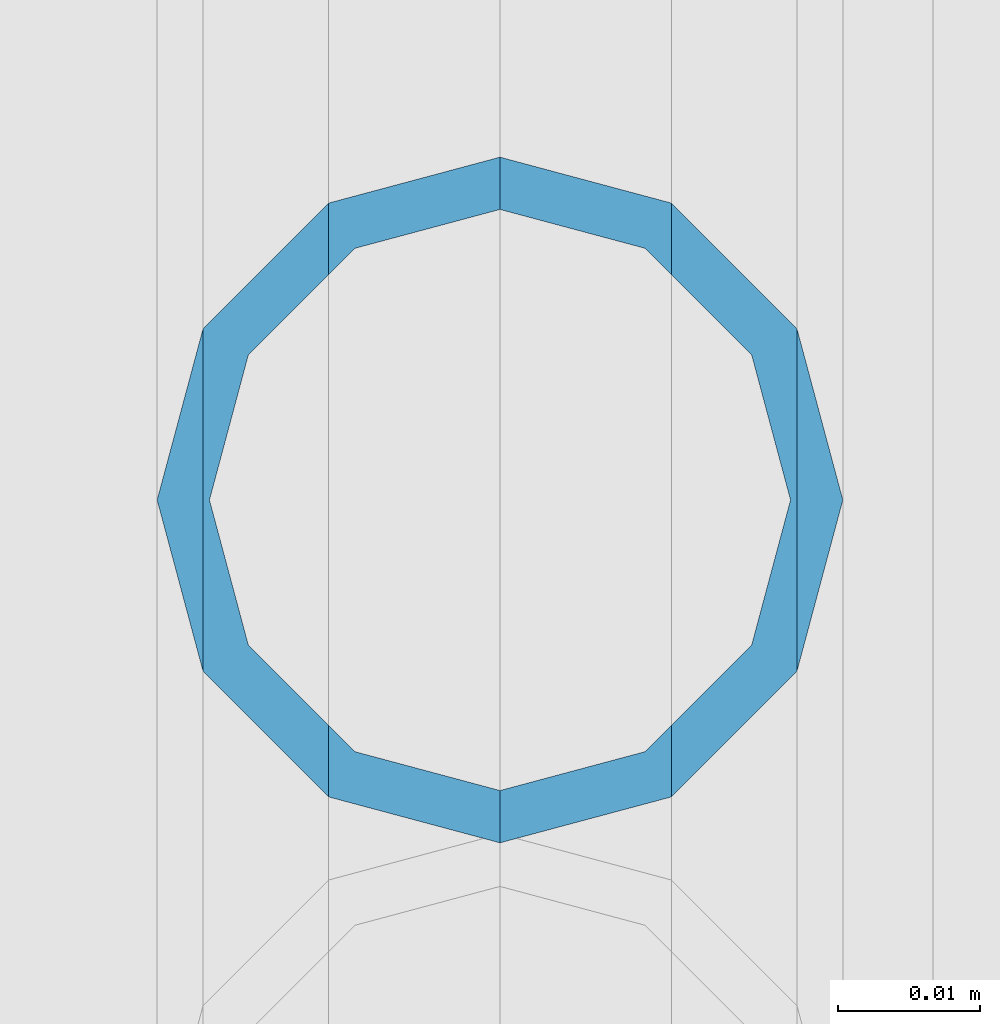
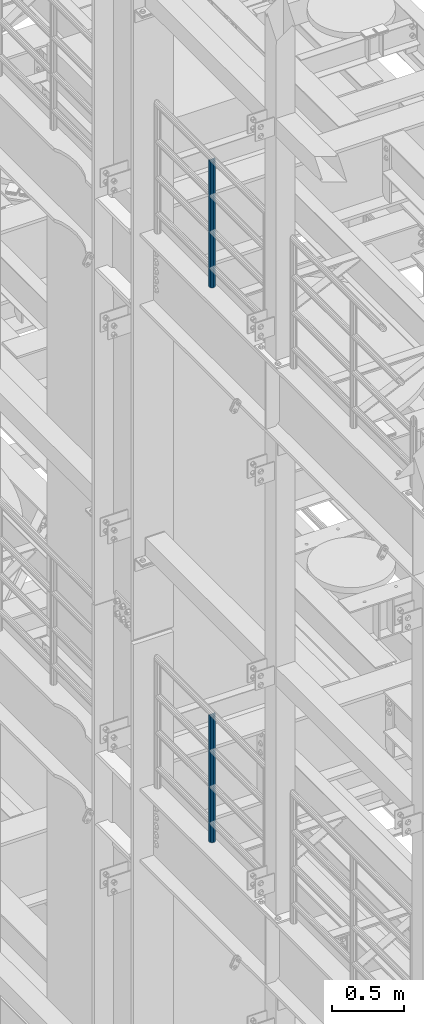
# One storey, part 682 of 1876: 2 columns, 2 elements without a shape of their own.
"""IFC2X3 building model written with IfcOpenShell, lengths in millimetres."""

from ifc_helpers import new_model, si_unit, frame, origin_with_axes, place, context, subcontext, project, spatial, faceted_brep, material, type_object, element, aggregate, save


model = new_model("IFC2X3")

# Units and contexts
model_context = context("Model", 3, precision=1e-05, world=origin_with_axes())
body_context = subcontext(model_context, "Body", "Model", "MODEL_VIEW")
ifc_project = project(units=[si_unit("LENGTHUNIT", "METRE", prefix="MILLI"), si_unit("AREAUNIT", "SQUARE_METRE"), si_unit("VOLUMEUNIT", "CUBIC_METRE"), si_unit("MASSUNIT", "GRAM", prefix="KILO"), si_unit("TIMEUNIT", "SECOND"), si_unit("PLANEANGLEUNIT", "RADIAN"), si_unit("SOLIDANGLEUNIT", "STERADIAN"), si_unit("THERMODYNAMICTEMPERATUREUNIT", "DEGREE_CELSIUS"), si_unit("LUMINOUSINTENSITYUNIT", "LUMEN")], contexts=[model_context])

# Site, building, storey
site_placement = place(None, origin_with_axes())
site = spatial("IfcSite", under=ifc_project, at=site_placement, CompositionType="ELEMENT")
building_placement = place(site_placement, origin_with_axes())
building = spatial("IfcBuilding", under=site, at=building_placement, Name="Undefined", CompositionType="ELEMENT")
storey_placement = place(building_placement, origin_with_axes())
storey = spatial("IfcBuildingStorey", under=building, at=storey_placement, Name="Undefined", CompositionType="ELEMENT", Elevation=0.0)

# Assembly, column
assembly_1_placement = place(storey_placement, origin_with_axes())
assembly_1 = element("IfcElementAssembly", 1, at=assembly_1_placement, inside=storey, Name="RAIL", AssemblyPlace="NOTDEFINED", PredefinedType="RIGID_FRAME")
ifc_material = material()
column_type = type_object("IfcColumnType", Name="PIPE1-1/2SCH40", PredefinedType="NOTDEFINED")
column_1_placement = place(assembly_1_placement, frame((-1.81898940354586e-12, 430.212499999999, 17983.2), z_axis=(0.0, 1.0, 0.0), x_axis=(0.0, 0.0, 1.0)))
column_1 = element("IfcColumn", 2, at=column_1_placement, type_object=column_type, material=ifc_material, Name="POST", ObjectType="PIPE1-1/2SCH40", context=body_context, shape_type="Brep", body=[
    faceted_brep([(1055.42780700668, -12.0650000000001, 20.8971929933186), (1055.42780700668, -12.0650000000001, 15.8661214311805), (1054.93437856882, -10.2235000000001, 17.7076214311801), (1052.195, 0.0, 20.4470000000001), (1052.195, 0.0, 24.1300000000001), (1054.93437856882, 10.2235000000001, 17.7076214311801), (1055.42780700668, 12.0650000000001, 15.8661214311805), (1055.42780700668, 12.0650000000001, 20.8971929933186), (1076.325, 24.1300000000001, 0.0), (1064.26, 20.8971929933184, 12.0649999999996), (1064.25999999999, 20.8971929933186, -12.0649999999996), (1061.07042843786, 17.7076214311803, 10.2235000000001), (1063.80980700668, 20.4469999999999, 0.0), (1061.07042843786, 17.7076214311803, -10.2235000000001), (1055.42780700668, 12.0650000000001, -15.8661214311805), (1055.42780700667, 12.0649999999996, -20.8971929933186), (1054.93437856882, 10.2235000000001, -17.7076214311801), (1052.195, 0.0, -20.4470000000001), (1052.19499999999, 0.0, -24.1300000000001), (1055.42780700668, -12.0650000000001, -15.8661214311805), (1055.42780700667, -12.0649999999996, -20.8971929933186), (1054.93437856882, -10.2235000000001, -17.7076214311801), (1076.325, -24.1300000000001, 0.0), (1064.25999999999, -20.8971929933186, -12.0649999999996), (1064.26, -20.8971929933184, 12.0649999999996), (1061.07042843786, -17.7076214311803, -10.2235000000001), (1063.80980700668, -20.4469999999999, 0.0), (1061.07042843786, -17.7076214311803, 10.2235000000001), (0.0, -20.8971929933184, -12.0649999999996), (0.0, -12.0650000000001, -20.8971929933186), (-1.45519152283669e-11, 0.0, -24.130000000001), (0.0, 12.0650000000001, -20.8971929933186), (0.0, 20.8971929933184, -12.0649999999996), (0.0, 24.1299999999992, 0.0), (0.0, 20.8971929933184, 12.0649999999996), (0.0, 12.0650000000001, 20.8971929933186), (-1.45519152283669e-11, 0.0, 24.130000000001), (0.0, -12.0650000000001, 20.8971929933186), (0.0, -20.8971929933184, 12.0649999999996), (0.0, -24.1299999999992, 0.0), (0.0, -17.7076214311803, -10.2235000000001), (0.0, -10.2235000000001, -17.7076214311801), (-1.45519152283669e-11, 0.0, -20.4470000000001), (0.0, 10.2235000000001, -17.7076214311801), (0.0, 17.7076214311803, -10.2235000000001), (0.0, 20.4469999999999, 0.0), (0.0, 17.7076214311803, 10.2235000000001), (0.0, 10.2235000000001, 17.7076214311801), (-1.45519152283669e-11, 0.0, 20.4470000000001), (0.0, -10.2235000000001, 17.7076214311801), (0.0, -17.7076214311803, 10.2235000000001), (0.0, -20.4469999999999, 0.0)], [[[0, 1, 2, 3, 4]], [[4, 3, 5, 6, 7]], [[8, 9, 10]], [[7, 6, 11, 12, 13, 14, 15, 10, 9]], [[16, 17, 18, 15, 14]], [[19, 20, 18, 17, 21]], [[22, 23, 24]], [[24, 23, 20, 19, 25, 26, 27, 1, 0]], [[28, 29, 20, 23]], [[29, 30, 18, 20]], [[30, 31, 15, 18]], [[31, 32, 10, 15]], [[32, 33, 8, 10]], [[33, 34, 9, 8]], [[34, 35, 7, 9]], [[35, 36, 4, 7]], [[36, 37, 0, 4]], [[37, 38, 24, 0]], [[38, 39, 22, 24]], [[39, 28, 23, 22]], [[38, 37, 36, 35, 34, 33, 32, 31, 30, 29, 28, 39], [40, 41, 42, 43, 44, 45, 46, 47, 48, 49, 50, 51]], [[40, 51, 26, 25]], [[21, 41, 40, 25, 19]], [[42, 41, 21, 17]], [[43, 42, 17, 16]], [[44, 43, 16, 14, 13]], [[45, 44, 13, 12]], [[46, 45, 12, 11]], [[5, 47, 46, 11, 6]], [[48, 47, 5, 3]], [[49, 48, 3, 2]], [[50, 49, 2, 1, 27]], [[51, 50, 27, 26]]]),
])
aggregate(assembly_1, [column_1])

assembly_2_placement = place(storey_placement, origin_with_axes())
assembly_2 = element("IfcElementAssembly", 3, at=assembly_2_placement, inside=storey, Name="RAIL", AssemblyPlace="NOTDEFINED", PredefinedType="RIGID_FRAME")
column_2_placement = place(assembly_2_placement, frame((-1.81898940354586e-12, 430.212499999999, 13309.6), z_axis=(0.0, 1.0, 0.0), x_axis=(0.0, 0.0, 1.0)))
column_2 = element("IfcColumn", 4, at=column_2_placement, type_object=column_type, material=ifc_material, Name="POST", ObjectType="PIPE1-1/2SCH40", context=body_context, shape_type="Brep", body=[
    faceted_brep([(1055.42780700668, -12.0650000000001, 20.8971929933186), (1055.42780700668, -12.0650000000001, 15.8661214311805), (1054.93437856882, -10.2235000000001, 17.7076214311801), (1052.195, 0.0, 20.4470000000001), (1052.195, 0.0, 24.1300000000001), (1054.93437856882, 10.2235000000001, 17.7076214311801), (1055.42780700668, 12.0650000000001, 15.8661214311805), (1055.42780700668, 12.0650000000001, 20.8971929933186), (1076.325, 24.1300000000001, 0.0), (1064.26, 20.8971929933184, 12.0649999999996), (1064.25999999999, 20.8971929933186, -12.0649999999996), (1061.07042843786, 17.7076214311803, 10.2235000000001), (1063.80980700668, 20.4469999999999, 0.0), (1061.07042843786, 17.7076214311803, -10.2235000000001), (1055.42780700668, 12.0650000000001, -15.8661214311805), (1055.42780700667, 12.0649999999996, -20.8971929933186), (1054.93437856882, 10.2235000000001, -17.7076214311801), (1052.195, 0.0, -20.4470000000001), (1052.19499999999, 0.0, -24.1300000000001), (1055.42780700668, -12.0650000000001, -15.8661214311805), (1055.42780700667, -12.0649999999996, -20.8971929933186), (1054.93437856882, -10.2235000000001, -17.7076214311801), (1076.325, -24.1300000000001, 0.0), (1064.25999999999, -20.8971929933186, -12.0649999999996), (1064.26, -20.8971929933184, 12.0649999999996), (1061.07042843786, -17.7076214311803, -10.2235000000001), (1063.80980700668, -20.4469999999999, 0.0), (1061.07042843786, -17.7076214311803, 10.2235000000001), (0.0, -20.8971929933184, -12.0649999999996), (0.0, -12.0650000000001, -20.8971929933186), (-1.45519152283669e-11, 0.0, -24.130000000001), (0.0, 12.0650000000001, -20.8971929933186), (0.0, 20.8971929933184, -12.0649999999996), (0.0, 24.1299999999992, 0.0), (0.0, 20.8971929933184, 12.0649999999996), (0.0, 12.0650000000001, 20.8971929933186), (-1.45519152283669e-11, 0.0, 24.130000000001), (0.0, -12.0650000000001, 20.8971929933186), (0.0, -20.8971929933184, 12.0649999999996), (0.0, -24.1299999999992, 0.0), (0.0, -17.7076214311803, -10.2235000000001), (0.0, -10.2235000000001, -17.7076214311801), (-1.45519152283669e-11, 0.0, -20.4470000000001), (0.0, 10.2235000000001, -17.7076214311801), (0.0, 17.7076214311803, -10.2235000000001), (0.0, 20.4469999999999, 0.0), (0.0, 17.7076214311803, 10.2235000000001), (0.0, 10.2235000000001, 17.7076214311801), (-1.45519152283669e-11, 0.0, 20.4470000000001), (0.0, -10.2235000000001, 17.7076214311801), (0.0, -17.7076214311803, 10.2235000000001), (0.0, -20.4469999999999, 0.0)], [[[0, 1, 2, 3, 4]], [[4, 3, 5, 6, 7]], [[8, 9, 10]], [[7, 6, 11, 12, 13, 14, 15, 10, 9]], [[16, 17, 18, 15, 14]], [[19, 20, 18, 17, 21]], [[22, 23, 24]], [[24, 23, 20, 19, 25, 26, 27, 1, 0]], [[28, 29, 20, 23]], [[29, 30, 18, 20]], [[30, 31, 15, 18]], [[31, 32, 10, 15]], [[32, 33, 8, 10]], [[33, 34, 9, 8]], [[34, 35, 7, 9]], [[35, 36, 4, 7]], [[36, 37, 0, 4]], [[37, 38, 24, 0]], [[38, 39, 22, 24]], [[39, 28, 23, 22]], [[38, 37, 36, 35, 34, 33, 32, 31, 30, 29, 28, 39], [40, 41, 42, 43, 44, 45, 46, 47, 48, 49, 50, 51]], [[40, 51, 26, 25]], [[21, 41, 40, 25, 19]], [[42, 41, 21, 17]], [[43, 42, 17, 16]], [[44, 43, 16, 14, 13]], [[45, 44, 13, 12]], [[46, 45, 12, 11]], [[5, 47, 46, 11, 6]], [[48, 47, 5, 3]], [[49, 48, 3, 2]], [[50, 49, 2, 1, 27]], [[51, 50, 27, 26]]]),
])
aggregate(assembly_2, [column_2])

save(model, "model.ifc")
